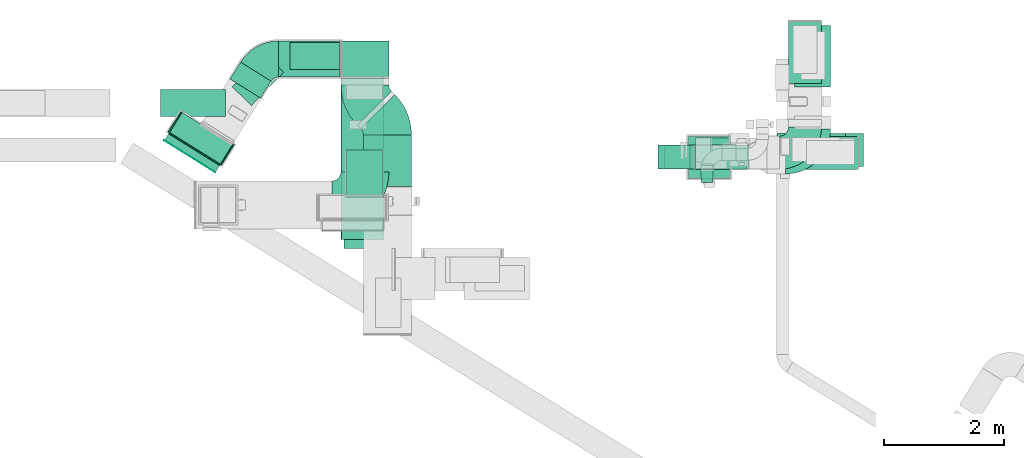
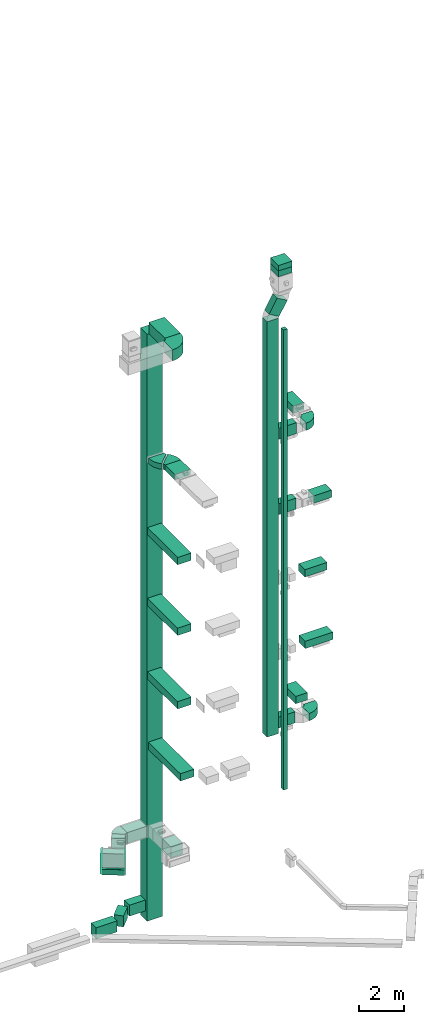
# One storey, part 6 of 25: 27 flow segments, 10 flow fittings, 1 flow terminal.
"""IFC2X3 building model written with IfcOpenShell, lengths in millimetres."""

from ifc_helpers import new_model, entity, si_unit, converted_unit, derived_unit, direction, frame, frame_2d, origin, origin_2d_with_axis, place, context, subcontext, project, spatial, polyline, circle_curve, parameter, trimmed, segment, composite_curve, rectangle, outline, extrude, faceted_brep, source, transform, mapped, material, type_object, type_shapes, element, save


model = new_model("IFC2X3")

# Units and contexts
model_context = context("Model", 3, precision=0.01, world=origin(), true_north=direction((6.12303176911189e-17, 1.0)))
body_context = subcontext(model_context, "Body", "Model", "MODEL_VIEW")
ifc_project = project(units=[si_unit("LENGTHUNIT", "METRE", prefix="MILLI"), si_unit("AREAUNIT", "SQUARE_METRE"), si_unit("VOLUMEUNIT", "CUBIC_METRE"), converted_unit("PLANEANGLEUNIT", "DEGREE", entity("IfcRatioMeasure", 0.0174532925199433), si_unit("PLANEANGLEUNIT", "RADIAN"), dimensions=[0, 0, 0, 0, 0, 0, 0]), si_unit("MASSUNIT", "GRAM", prefix="KILO"), derived_unit("MASSDENSITYUNIT", [(si_unit("MASSUNIT", "GRAM", prefix="KILO"), 1), (si_unit("LENGTHUNIT", "METRE"), -3)]), derived_unit("MOMENTOFINERTIAUNIT", [(si_unit("LENGTHUNIT", "METRE"), 4)]), si_unit("TIMEUNIT", "SECOND"), si_unit("FREQUENCYUNIT", "HERTZ"), si_unit("THERMODYNAMICTEMPERATUREUNIT", "DEGREE_CELSIUS"), derived_unit("THERMALTRANSMITTANCEUNIT", [(si_unit("MASSUNIT", "GRAM", prefix="KILO"), 1), (si_unit("THERMODYNAMICTEMPERATUREUNIT", "KELVIN"), -1), (si_unit("TIMEUNIT", "SECOND"), -3)]), derived_unit("VOLUMETRICFLOWRATEUNIT", [(si_unit("LENGTHUNIT", "METRE"), 3), (si_unit("TIMEUNIT", "SECOND"), -1)]), derived_unit("MASSFLOWRATEUNIT", [(si_unit("MASSUNIT", "GRAM", prefix="KILO"), 1), (si_unit("TIMEUNIT", "SECOND"), -1)]), derived_unit("ROTATIONALFREQUENCYUNIT", [(si_unit("TIMEUNIT", "SECOND"), -1)]), si_unit("ELECTRICCURRENTUNIT", "AMPERE"), si_unit("ELECTRICVOLTAGEUNIT", "VOLT"), si_unit("POWERUNIT", "WATT"), si_unit("FORCEUNIT", "NEWTON", prefix="KILO"), si_unit("ILLUMINANCEUNIT", "LUX"), si_unit("LUMINOUSFLUXUNIT", "LUMEN"), si_unit("LUMINOUSINTENSITYUNIT", "CANDELA"), derived_unit("USERDEFINED", [(si_unit("MASSUNIT", "GRAM", prefix="KILO"), -1), (si_unit("LENGTHUNIT", "METRE"), -2), (si_unit("TIMEUNIT", "SECOND"), 3), (si_unit("LUMINOUSFLUXUNIT", "LUMEN"), 1)]), derived_unit("LINEARVELOCITYUNIT", [(si_unit("LENGTHUNIT", "METRE"), 1), (si_unit("TIMEUNIT", "SECOND"), -1)]), si_unit("PRESSUREUNIT", "PASCAL"), derived_unit("USERDEFINED", [(si_unit("LENGTHUNIT", "METRE"), -2), (si_unit("MASSUNIT", "GRAM", prefix="KILO"), 1), (si_unit("TIMEUNIT", "SECOND"), -2)]), derived_unit("LINEARFORCEUNIT", [(si_unit("MASSUNIT", "GRAM", prefix="KILO"), 1), (si_unit("LENGTHUNIT", "METRE"), 1), (si_unit("TIMEUNIT", "SECOND"), -2), (si_unit("LENGTHUNIT", "METRE"), -1)]), derived_unit("PLANARFORCEUNIT", [(si_unit("MASSUNIT", "GRAM", prefix="KILO"), 1), (si_unit("LENGTHUNIT", "METRE"), 1), (si_unit("TIMEUNIT", "SECOND"), -2), (si_unit("LENGTHUNIT", "METRE"), -2)])], contexts=[model_context])

# Site, building, storey
site_placement = place(None, origin())
site = spatial("IfcSite", under=ifc_project, at=site_placement, CompositionType="ELEMENT")
building_placement = place(site_placement, origin())
building = spatial("IfcBuilding", under=site, at=building_placement, CompositionType="ELEMENT")
storey_placement = place(building_placement, origin())
storey = spatial("IfcBuildingStorey", under=building, at=storey_placement, CompositionType="ELEMENT", Elevation=0.0)

# Flow segments
duct_segment_type_1 = type_object("IfcDuctSegmentType", PredefinedType="NOTDEFINED")
flow_segment_1_placement = place(storey_placement, frame((10049.73, 14594.08, 7185.13)))
element("IfcFlowSegment", 1, at=flow_segment_1_placement, inside=storey, type_object=duct_segment_type_1, context=body_context, shape_type="SweptSolid", body=[
    extrude(rectangle(XDim=896.28958332103, YDim=400.0, at=origin_2d_with_axis()), frame((448.14, 200.0, 0.0), z_axis=(0.0, 0.0, 1.0), x_axis=(-1.0, 0.0, 0.0)), (0.0, 0.0, 1.0), 600.0),
])
flow_segment_2_placement = place(storey_placement, frame((10049.73, 14469.56, 18900.0)))
element("IfcFlowSegment", 2, at=flow_segment_2_placement, inside=storey, type_object=duct_segment_type_1, context=body_context, shape_type="SweptSolid", body=[
    extrude(rectangle(XDim=860.000000000108, YDim=400.0, at=origin_2d_with_axis()), frame((430.0, 200.0, 0.0)), (0.0, 0.0, 1.0), 599.999999999998),
])
flow_segment_3_placement = place(storey_placement, frame((11848.49, 14469.56, 18900.0)))
element("IfcFlowSegment", 3, at=flow_segment_3_placement, inside=storey, type_object=duct_segment_type_1, context=body_context, shape_type="SweptSolid", body=[
    extrude(rectangle(XDim=897.282341040552, YDim=550.000000000001, at=origin_2d_with_axis()), frame((448.64, 275.0, 0.0)), (0.0, 0.0, 1.0), 400.0),
])
flow_segment_4_placement = place(storey_placement, frame((10049.73, 14472.56, 23000.0)))
element("IfcFlowSegment", 4, at=flow_segment_4_placement, inside=storey, type_object=duct_segment_type_1, context=body_context, shape_type="SweptSolid", body=[
    extrude(rectangle(XDim=896.035482908388, YDim=400.0, at=origin_2d_with_axis()), frame((448.02, 200.0, 0.0)), (0.0, 0.0, 1.0), 600.000000000002),
])
flow_segment_5_placement = place(storey_placement, frame((11599.64, 15901.49, 23000.0)))
element("IfcFlowSegment", 5, at=flow_segment_5_placement, inside=storey, type_object=duct_segment_type_1, context=body_context, shape_type="SweptSolid", body=[
    extrude(rectangle(XDim=1032.28234104056, YDim=550.000000000001, at=origin_2d_with_axis()), frame((275.0, 516.14, 0.0), z_axis=(0.0, 0.0, 1.0), x_axis=(0.0, 1.0, 0.0)), (0.0, 0.0, 1.0), 399.999999999996),
])
flow_segment_6_placement = place(storey_placement, frame((10144.72, 14250.84, 4000.0)))
element("IfcFlowSegment", 6, at=flow_segment_6_placement, inside=storey, type_object=duct_segment_type_1, context=body_context, shape_type="SweptSolid", body=[
    extrude(rectangle(XDim=199.999999999998, YDim=200.0, at=origin_2d_with_axis()), frame((100.0, 100.0, 0.0), z_axis=(0.0, 0.0, 1.0), x_axis=(0.0, -1.0, 0.0)), (0.0, 0.0, 1.0), 25050.0),
])
flow_segment_7_placement = place(storey_placement, frame((9429.73, 14472.56, 7000.0)))
element("IfcFlowSegment", 7, at=flow_segment_7_placement, inside=storey, type_object=duct_segment_type_1, context=body_context, shape_type="SweptSolid", body=[
    extrude(rectangle(XDim=400.0, YDim=600.0, at=origin_2d_with_axis()), frame((300.0, 200.0, 0.0), z_axis=(0.0, 0.0, 1.0), x_axis=(0.0, 1.0, 0.0)), (0.0, 0.0, 1.0), 22618.0236689535),
])
flow_segment_8_placement = place(storey_placement, frame((1285.71, 14551.05, 2050.0)))
element("IfcFlowSegment", 8, at=flow_segment_8_placement, inside=storey, type_object=duct_segment_type_1, context=body_context, shape_type="SweptSolid", body=[
    extrude(rectangle(XDim=1000.0, YDim=400.000000000001, at=origin_2d_with_axis()), frame((530.01, 434.57, 0.0), z_axis=(0.0, 0.0, 1.0), x_axis=(0.848048096097044, -0.529919264328235, 0.0)), (0.0, 0.0, 1.0), 1100.0),
])
flow_segment_9_placement = place(storey_placement, frame((11423.63, 14520.08, 11100.0)))
element("IfcFlowSegment", 9, at=flow_segment_9_placement, inside=storey, type_object=duct_segment_type_1, context=body_context, shape_type="SweptSolid", body=[
    extrude(rectangle(XDim=1424.85916912395, YDim=550.000000000001, at=origin_2d_with_axis()), frame((712.43, 275.0, 0.0)), (0.0, 0.0, 1.0), 400.0),
])
flow_segment_10_placement = place(storey_placement, frame((11408.63, 14519.08, 15000.0)))
element("IfcFlowSegment", 10, at=flow_segment_10_placement, inside=storey, type_object=duct_segment_type_1, context=body_context, shape_type="SweptSolid", body=[
    extrude(rectangle(XDim=1142.14151738165, YDim=550.000000000001, at=origin_2d_with_axis()), frame((571.07, 275.0, 0.0), z_axis=(0.0, 0.0, 1.0), x_axis=(-1.0, 0.0, 0.0)), (0.0, 0.0, 1.0), 400.0),
])
flow_segment_11_placement = place(storey_placement, frame((11700.22, 15840.38, 7200.0)))
element("IfcFlowSegment", 11, at=flow_segment_11_placement, inside=storey, type_object=duct_segment_type_1, context=body_context, shape_type="SweptSolid", body=[
    extrude(rectangle(XDim=1025.0, YDim=600.0, at=origin_2d_with_axis()), frame((300.0, 512.5, 0.0), z_axis=(0.0, 0.0, 1.0), x_axis=(0.0, 1.0, 0.0)), (0.0, 0.0, 1.0), 400.0),
])
flow_segment_12_placement = place(storey_placement, frame((9532.4, 14472.56, 29693.78)))
element("IfcFlowSegment", 12, at=flow_segment_12_placement, inside=storey, type_object=duct_segment_type_1, context=body_context, shape_type="SweptSolid", body=[
    extrude(rectangle(XDim=600.000000000002, YDim=400.000000000002, at=frame_2d((0.0, 0.0), x_axis=(0.0, 1.0))), frame((258.93, 200.0, 151.5), z_axis=(0.505012393824036, 0.0, 0.863112091262842), x_axis=(0.0, 1.0, 0.0)), (0.0, 0.0, 1.0), 845.129520297064),
])
flow_segment_13_placement = place(storey_placement, frame((9929.73, 14322.56, 31980.0)))
element("IfcFlowSegment", 13, at=flow_segment_13_placement, inside=storey, type_object=duct_segment_type_1, context=body_context, shape_type="SweptSolid", body=[
    extrude(rectangle(XDim=700.000000000001, YDim=699.999999999999, at=origin_2d_with_axis()), frame((350.0, 350.0, 0.0), z_axis=(0.0, 0.0, 1.0), x_axis=(0.0, 1.0, 0.0)), (0.0, 0.0, 1.0), 320.64365169538),
])
duct_segment_type_2 = type_object("IfcDuctSegmentType", PredefinedType="NOTDEFINED")
flow_segment_14_placement = place(storey_placement, frame((4143.33, 14427.57, 30000.0)))
element("IfcFlowSegment", 14, at=flow_segment_14_placement, inside=storey, type_object=duct_segment_type_2, context=body_context, shape_type="SweptSolid", body=[
    extrude(rectangle(XDim=1432.40750074229, YDim=800.0, at=origin_2d_with_axis()), frame((400.0, 716.2, 0.0), z_axis=(0.0, 0.0, 1.0), x_axis=(0.0, -1.0, 0.0)), (0.0, 0.0, 1.0), 600.000000000002),
])
flow_segment_15_placement = place(storey_placement, frame((4143.33, 16009.98, -2100.0)))
element("IfcFlowSegment", 15, at=flow_segment_15_placement, inside=storey, type_object=duct_segment_type_2, context=body_context, shape_type="SweptSolid", body=[
    extrude(rectangle(XDim=599.999999999998, YDim=800.0, at=origin_2d_with_axis()), frame((400.0, 300.0, 0.0), z_axis=(0.0, 0.0, 1.0), x_axis=(0.0, 1.0, 0.0)), (0.0, 0.0, 1.0), 31950.0),
])
flow_segment_16_placement = place(storey_placement, frame((4519.66, 14181.61, 22900.0)))
element("IfcFlowSegment", 16, at=flow_segment_16_placement, inside=storey, type_object=duct_segment_type_2, context=body_context, shape_type="SweptSolid", body=[
    extrude(rectangle(XDim=862.182540694804, YDim=800.0, at=origin_2d_with_axis()), frame((400.0, 431.09, 0.0), z_axis=(0.0, 0.0, 1.0), x_axis=(0.0, 1.0, 0.0)), (0.0, 0.0, 1.0), 300.000000000001),
])
flow_segment_17_placement = place(storey_placement, frame((4150.45, 13299.66, 18950.0)))
element("IfcFlowSegment", 17, at=flow_segment_17_placement, inside=storey, type_object=duct_segment_type_2, context=body_context, shape_type="SweptSolid", body=[
    extrude(rectangle(XDim=2690.31743527313, YDim=700.0, at=origin_2d_with_axis()), frame((350.0, 1345.16, 0.0), z_axis=(0.0, 0.0, 1.0), x_axis=(0.0, 1.0, 0.0)), (0.0, 0.0, 1.0), 400.0),
])
flow_segment_18_placement = place(storey_placement, frame((4199.45, 13150.47, 7250.0)))
element("IfcFlowSegment", 18, at=flow_segment_18_placement, inside=storey, type_object=duct_segment_type_2, context=body_context, shape_type="SweptSolid", body=[
    extrude(rectangle(XDim=2839.50726337812, YDim=700.0, at=origin_2d_with_axis()), frame((350.0, 1419.75, 0.0), z_axis=(0.0, 0.0, 1.0), x_axis=(0.0, 1.0, 0.0)), (0.0, 0.0, 1.0), 400.0),
])
flow_segment_19_placement = place(storey_placement, frame((4149.45, 13299.66, 11100.0)))
element("IfcFlowSegment", 19, at=flow_segment_19_placement, inside=storey, type_object=duct_segment_type_2, context=body_context, shape_type="SweptSolid", body=[
    extrude(rectangle(XDim=2690.31743527277, YDim=700.0, at=origin_2d_with_axis()), frame((350.0, 1345.16, 0.0), z_axis=(0.0, 0.0, 1.0), x_axis=(0.0, 1.0, 0.0)), (0.0, 0.0, 1.0), 400.0),
])
flow_segment_20_placement = place(storey_placement, frame((4150.45, 13299.66, 15100.0)))
element("IfcFlowSegment", 20, at=flow_segment_20_placement, inside=storey, type_object=duct_segment_type_2, context=body_context, shape_type="SweptSolid", body=[
    extrude(rectangle(XDim=2690.31743527295, YDim=700.0, at=origin_2d_with_axis()), frame((350.0, 1345.16, 0.0), z_axis=(0.0, 0.0, 1.0), x_axis=(0.0, 1.0, 0.0)), (0.0, 0.0, 1.0), 400.0),
])
flow_segment_21_placement = place(storey_placement, frame((4238.74, 14052.5, 2500.0)))
element("IfcFlowSegment", 21, at=flow_segment_21_placement, inside=storey, type_object=duct_segment_type_2, context=body_context, shape_type="SweptSolid", body=[
    extrude(rectangle(XDim=738.844290776113, YDim=600.0, at=origin_2d_with_axis()), frame((300.0, 369.42, 0.0), z_axis=(0.0, 0.0, 1.0), x_axis=(0.0, -1.0, 0.0)), (0.0, 0.0, 1.0), 600.0),
])
flow_segment_22_placement = place(storey_placement, frame((3108.62, 16009.98, 2485.0)))
element("IfcFlowSegment", 22, at=flow_segment_22_placement, inside=storey, type_object=duct_segment_type_2, context=body_context, shape_type="SweptSolid", body=[
    extrude(rectangle(XDim=1014.71471811025, YDim=600.0, at=origin_2d_with_axis()), frame((507.36, 300.0, 0.0), z_axis=(0.0, 0.0, 1.0), x_axis=(-1.0, 0.0, 0.0)), (0.0, 0.0, 1.0), 600.0),
])
flow_segment_23_placement = place(storey_placement, frame((1205.05, 14422.63, 2100.0)))
element("IfcFlowSegment", 23, at=flow_segment_23_placement, inside=storey, type_object=duct_segment_type_2, context=body_context, shape_type="SweptSolid", body=[
    extrude(rectangle(XDim=131.648976761312, YDim=1000.0, at=origin_2d_with_axis()), frame((458.91, 320.78, 0.0), z_axis=(0.0, 0.0, 1.0), x_axis=(0.529919264233203, 0.848048096156427, 0.0)), (0.0, 0.0, 1.0), 300.0),
])
flow_segment_24_placement = place(storey_placement, frame((3296.53, 16131.82, -1600.0)))
element("IfcFlowSegment", 24, at=flow_segment_24_placement, inside=storey, type_object=duct_segment_type_2, context=body_context, shape_type="SweptSolid", body=[
    extrude(rectangle(XDim=826.797184161113, YDim=449.999999999999, at=origin_2d_with_axis()), frame((413.4, 225.0, 0.0), z_axis=(0.0, 0.0, 1.0), x_axis=(-1.0, 0.0, 0.0)), (0.0, 0.0, 1.0), 600.0),
])
flow_segment_25_placement = place(storey_placement, frame((2331.18, 15533.31, -1600.0)))
element("IfcFlowSegment", 25, at=flow_segment_25_placement, inside=storey, type_object=duct_segment_type_2, context=body_context, shape_type="SweptSolid", body=[
    extrude(rectangle(XDim=768.361021095479, YDim=450.000000000001, at=origin_2d_with_axis()), frame((428.73, 432.65, 0.0), z_axis=(0.0, 0.0, 1.0), x_axis=(-0.694658370458998, -0.719339800338651, 0.0)), (0.0, 0.0, 1.0), 600.0),
])
flow_segment_26_placement = place(storey_placement, frame((2297.27, 15658.91, 2485.0)))
element("IfcFlowSegment", 26, at=flow_segment_26_placement, inside=storey, type_object=duct_segment_type_2, context=body_context, shape_type="SweptSolid", body=[
    extrude(rectangle(XDim=330.818571009889, YDim=600.0, at=origin_2d_with_axis()), frame((342.07, 299.25, 0.0), z_axis=(0.0, 0.0, 1.0), x_axis=(-0.529919264328237, -0.848048096097043, 0.0)), (0.0, 0.0, 1.0), 600.0),
])
flow_segment_27_placement = place(storey_placement, frame((1140.11, 15350.1, -1600.0)))
element("IfcFlowSegment", 27, at=flow_segment_27_placement, inside=storey, type_object=duct_segment_type_2, context=body_context, shape_type="SweptSolid", body=[
    extrude(rectangle(XDim=1083.1737579042, YDim=449.999999999999, at=origin_2d_with_axis()), frame((541.59, 225.0, 0.0), z_axis=(0.0, 0.0, 1.0), x_axis=(-1.0, 0.0, 0.0)), (0.0, 0.0, 1.0), 600.0),
])

# Flow terminal
ifc_material_1 = material()
air_terminal_type = type_object("IfcAirTerminalType", PredefinedType="NOTDEFINED", material=ifc_material_1)
shared_shape_1 = source(origin(), body_context, "Body", "SweptSolid", [
    extrude(rectangle(XDim=4.0, YDim=999.999999999999, at=origin_2d_with_axis()), frame((0.0, -2.0, -150.0), z_axis=(0.0, 0.0, 1.0), x_axis=(0.0, 1.0, 0.0)), (0.0, 0.0, 1.0), 300.000000000005),
])
type_shapes(air_terminal_type, [shared_shape_1])
flow_terminal_placement = place(storey_placement, frame((1629.08, 14687.59, 2250.0), z_axis=(0.0, 0.0, -1.0), x_axis=(-0.848048096156392, 0.52991926423326, 0.0)))
element("IfcFlowTerminal", 28, at=flow_terminal_placement, inside=storey, type_object=air_terminal_type, material=ifc_material_1, context=body_context, shape_type="MappedRepresentation", body=[
    mapped(shared_shape_1, transform((0.0, 0.0, 0.0), scale=1.0)),
])

# Flow fittings
ifc_material_2 = material()
duct_fitting_type_1 = type_object("IfcDuctFittingType", PredefinedType="NOTDEFINED", material=ifc_material_2)
shared_shape_2 = source(origin(), body_context, "Body", "SweptSolid", [
    extrude(rectangle(XDim=26.0960001120806, YDim=1000.0, at=origin_2d_with_axis()), frame((6.95, 0.0, -150.0)), (0.0, 0.0, 1.0), 300.0),
])
type_shapes(duct_fitting_type_1, [shared_shape_2])
flow_fitting_1_placement = place(storey_placement, frame((1709.44, 14816.2, 2250.0), z_axis=(0.0, 0.0, -1.0), x_axis=(-0.529919264233199, -0.84804809615643, 0.0)))
element("IfcFlowFitting", 29, at=flow_fitting_1_placement, inside=storey, type_object=duct_fitting_type_1, material=ifc_material_2, context=body_context, shape_type="MappedRepresentation", body=[
    mapped(shared_shape_2, transform((0.0, 0.0, 0.0), scale=1.0)),
])
duct_fitting_type_2 = type_object("IfcDuctFittingType", PredefinedType="NOTDEFINED", material=ifc_material_2)
shared_shape_3 = source(origin(), body_context, "Body", "SweptSolid", [
    extrude(rectangle(XDim=24.9999999999999, YDim=400.0, at=origin_2d_with_axis()), frame((12.5, 0.0, -550.0)), (0.0, 0.0, 1.0), 1100.0),
])
type_shapes(duct_fitting_type_2, [shared_shape_3])
for number, where, z_axis, x_axis in (
    (30, (1391.7, 15250.58, 2600.0), (0.0, 0.0, 1.0), (-0.848048096097044, 0.529919264328235, 0.0)),
    (31, (2239.74, 14720.66, 2600.0), (0.0, 0.0, 1.0), (0.848048096097044, -0.529919264328235, 0.0)),
):
    element("IfcFlowFitting", number, at=place(storey_placement, frame(where, z_axis=z_axis, x_axis=x_axis)), inside=storey, type_object=duct_fitting_type_2, material=ifc_material_2, context=body_context, shape_type="MappedRepresentation", body=[
        mapped(shared_shape_3, transform((0.0, 0.0, 0.0), scale=1.0)),
    ])
duct_fitting_type_3 = type_object("IfcDuctFittingType", PredefinedType="NOTDEFINED", material=ifc_material_2)
shared_shape_4 = source(origin(), body_context, "Body", "Brep", [
    faceted_brep([(300.0, -355.0, 355.0), (300.0, -355.0, -355.0), (300.0, 355.0, -355.0), (300.0, 355.0, 355.0), (0.0, -350.0, 350.0), (0.0, 350.0, 350.0), (0.0, 350.0, -350.0), (0.0, -350.0, -350.0)], [[[0, 1, 2, 3]], [[4, 5, 6, 7]], [[4, 7, 1, 0]], [[7, 6, 2, 1]], [[6, 5, 3, 2]], [[5, 4, 0, 3]]]),
])
type_shapes(duct_fitting_type_3, [shared_shape_4])
flow_fitting_2_placement = place(storey_placement, frame((10279.73, 14672.56, 32300.64), z_axis=(0.0, 1.0, 0.0), x_axis=(0.0, 0.0, 1.0)))
element("IfcFlowFitting", 32, at=flow_fitting_2_placement, inside=storey, type_object=duct_fitting_type_3, material=ifc_material_2, context=body_context, shape_type="MappedRepresentation", body=[
    mapped(shared_shape_4, transform((0.0, 0.0, 0.0), scale=1.0)),
])
duct_fitting_type_4 = type_object("IfcDuctFittingType", PredefinedType="NOTDEFINED", material=ifc_material_2)
shared_shape_5 = source(origin(), body_context, "Body", "SweptSolid", [
    extrude(outline(composite_curve([segment(polyline([(-525.0, -225.0), (75.0, -225.0)]), True, "CONTINUOUS"), segment(trimmed(circle_curve(frame_2d((225.0, -225.0), x_axis=(0.0, 1.0)), 150.0), [parameter(0.0)], [parameter(90.0)], True, "PARAMETER"), False, "CONTINUOUS"), segment(polyline([(225.0, -75.0), (225.0, 525.0)]), True, "CONTINUOUS"), segment(trimmed(circle_curve(frame_2d((225.0, -225.0), x_axis=(0.0, 1.0)), 750.0), [parameter(0.0)], [parameter(90.0)], True, "PARAMETER"), True, "CONTINUOUS")], self_intersect=False)), frame((-225.0, 225.0, -200.0), z_axis=(0.0, 0.0, 1.0), x_axis=(-1.0, 0.0, 0.0)), (0.0, 0.0, 1.0), 400.0),
])
type_shapes(duct_fitting_type_4, [shared_shape_5])
flow_fitting_3_placement = place(storey_placement, frame((12000.22, 14694.08, 7400.0)))
element("IfcFlowFitting", 33, at=flow_fitting_3_placement, inside=storey, type_object=duct_fitting_type_4, material=ifc_material_2, context=body_context, shape_type="MappedRepresentation", body=[
    mapped(shared_shape_5, transform((0.0, 0.0, 0.0), scale=1.0)),
])
duct_fitting_type_5 = type_object("IfcDuctFittingType", PredefinedType="NOTDEFINED", material=ifc_material_2)
shared_shape_6 = source(origin(), body_context, "Body", "SweptSolid", [
    extrude(outline(composite_curve([segment(polyline([(-675.0, -275.0), (125.0, -275.0)]), True, "CONTINUOUS"), segment(trimmed(circle_curve(frame_2d((275.0, -275.0), x_axis=(0.0, 1.0)), 150.0), [parameter(0.0)], [parameter(90.0)], True, "PARAMETER"), False, "CONTINUOUS"), segment(polyline([(275.0, -125.0), (275.0, 675.0)]), True, "CONTINUOUS"), segment(trimmed(circle_curve(frame_2d((275.0, -275.0), x_axis=(0.0, 1.0)), 950.0), [parameter(0.0)], [parameter(89.9999999999999)], True, "PARAMETER"), True, "CONTINUOUS")], self_intersect=False)), frame((-275.0, 275.0, -300.0), z_axis=(0.0, 0.0, 1.0), x_axis=(-1.0, 0.0, 0.0)), (0.0, 0.0, 1.0), 600.0),
])
type_shapes(duct_fitting_type_5, [shared_shape_6])
flow_fitting_4_placement = place(storey_placement, frame((4543.33, 13877.57, 30300.0)))
element("IfcFlowFitting", 34, at=flow_fitting_4_placement, inside=storey, type_object=duct_fitting_type_5, material=ifc_material_2, context=body_context, shape_type="MappedRepresentation", body=[
    mapped(shared_shape_6, transform((0.0, 0.0, 0.0), scale=1.0)),
])
duct_fitting_type_6 = type_object("IfcDuctFittingType", PredefinedType="NOTDEFINED", material=ifc_material_2)
shared_shape_7 = source(origin(), body_context, "Body", "SweptSolid", [
    extrude(outline(composite_curve([segment(polyline([(-405.77, -190.81), (194.23, -190.81)]), True, "CONTINUOUS"), segment(trimmed(circle_curve(frame_2d((344.23, -190.81), x_axis=(-0.529919264328242, 0.848048096097045)), 150.0), [parameter(0.0)], [parameter(57.9999999935792)], True, "PARAMETER"), False, "CONTINUOUS"), segment(polyline([(264.74, -63.6), (-53.21, 445.23)]), True, "CONTINUOUS"), segment(trimmed(circle_curve(frame_2d((344.23, -190.81), x_axis=(-0.529919264328242, 0.848048096097045)), 750.0), [parameter(0.0)], [parameter(57.9999999935792)], True, "PARAMETER"), True, "CONTINUOUS")], self_intersect=False)), frame((-58.63, 105.77, -300.0), z_axis=(0.0, 0.0, 1.0), x_axis=(-0.84804809609704, 0.529919264328242, 0.0)), (0.0, 0.0, 1.0), 600.0),
])
type_shapes(duct_fitting_type_6, [shared_shape_7])
flow_fitting_5_placement = place(storey_placement, frame((2859.18, 16309.98, 2785.0), z_axis=(0.0, 0.0, 1.0), x_axis=(-1.0, 0.0, 0.0)))
element("IfcFlowFitting", 35, at=flow_fitting_5_placement, inside=storey, type_object=duct_fitting_type_6, material=ifc_material_2, context=body_context, shape_type="MappedRepresentation", body=[
    mapped(shared_shape_7, transform((0.0, 0.0, 0.0), scale=1.0)),
])
duct_fitting_type_7 = type_object("IfcDuctFittingType", PredefinedType="NOTDEFINED", material=ifc_material_2)
shared_shape_8 = source(origin(), body_context, "Body", "SweptSolid", [
    extrude(outline(composite_curve([segment(polyline([(-487.5, -212.5), (62.5, -212.5)]), True, "CONTINUOUS"), segment(trimmed(circle_curve(frame_2d((212.5, -212.5), x_axis=(0.0, 1.0)), 150.0), [parameter(0.0)], [parameter(90.0)], True, "PARAMETER"), False, "CONTINUOUS"), segment(polyline([(212.5, -62.5), (212.5, 487.5)]), True, "CONTINUOUS"), segment(trimmed(circle_curve(frame_2d((212.5, -212.5), x_axis=(0.0, 1.0)), 700.0), [parameter(0.0)], [parameter(90.0)], True, "PARAMETER"), True, "CONTINUOUS")], self_intersect=False)), frame((-212.5, 212.5, -200.0), z_axis=(0.0, 0.0, 1.0), x_axis=(-1.0, 0.0, 0.0)), (0.0, 0.0, 1.0), 400.0),
])
type_shapes(duct_fitting_type_7, [shared_shape_8])
flow_fitting_6_placement = place(storey_placement, frame((11874.64, 14747.56, 23200.0)))
element("IfcFlowFitting", 36, at=flow_fitting_6_placement, inside=storey, type_object=duct_fitting_type_7, material=ifc_material_2, context=body_context, shape_type="MappedRepresentation", body=[
    mapped(shared_shape_8, transform((0.0, 0.0, 0.0), scale=1.0)),
])
duct_fitting_type_8 = type_object("IfcDuctFittingType", PredefinedType="NOTDEFINED", material=ifc_material_2)
shared_shape_9 = source(origin(), body_context, "Body", "SweptSolid", [
    extrude(outline(composite_curve([segment(polyline([(-480.55, -194.45), (319.45, -194.45)]), True, "CONTINUOUS"), segment(trimmed(circle_curve(frame_2d((469.45, -194.45), x_axis=(-0.707106781186553, 0.707106781186553)), 150.0), [parameter(0.0)], [parameter(45.0)], True, "PARAMETER"), False, "CONTINUOUS"), segment(polyline([(363.39, -88.39), (-202.3, 477.3)]), True, "CONTINUOUS"), segment(trimmed(circle_curve(frame_2d((469.45, -194.45), x_axis=(-0.707106781186553, 0.707106781186553)), 950.0), [parameter(0.0)], [parameter(45.0)], True, "PARAMETER"), True, "CONTINUOUS")], self_intersect=False)), frame((-33.36, 80.55, -150.0), z_axis=(0.0, 0.0, 1.0), x_axis=(-0.707106781186547, 0.707106781186548, 0.0)), (0.0, 0.0, 1.0), 300.0),
])
type_shapes(duct_fitting_type_8, [shared_shape_9])
for number, where, z_axis, x_axis in (
    (37, (4919.66, 15271.61, 23050.0), (0.0, 0.0, 1.0), (0.0, 1.0, 0.0)),
    (38, (4543.33, 15647.94, 23050.0), (0.0, 0.0, 1.0), (0.0, -1.0, 0.0)),
):
    element("IfcFlowFitting", number, at=place(storey_placement, frame(where, z_axis=z_axis, x_axis=x_axis)), inside=storey, type_object=duct_fitting_type_8, material=ifc_material_2, context=body_context, shape_type="MappedRepresentation", body=[
        mapped(shared_shape_9, transform((0.0, 0.0, 0.0), scale=1.0)),
    ])

save(model, "model.ifc")
